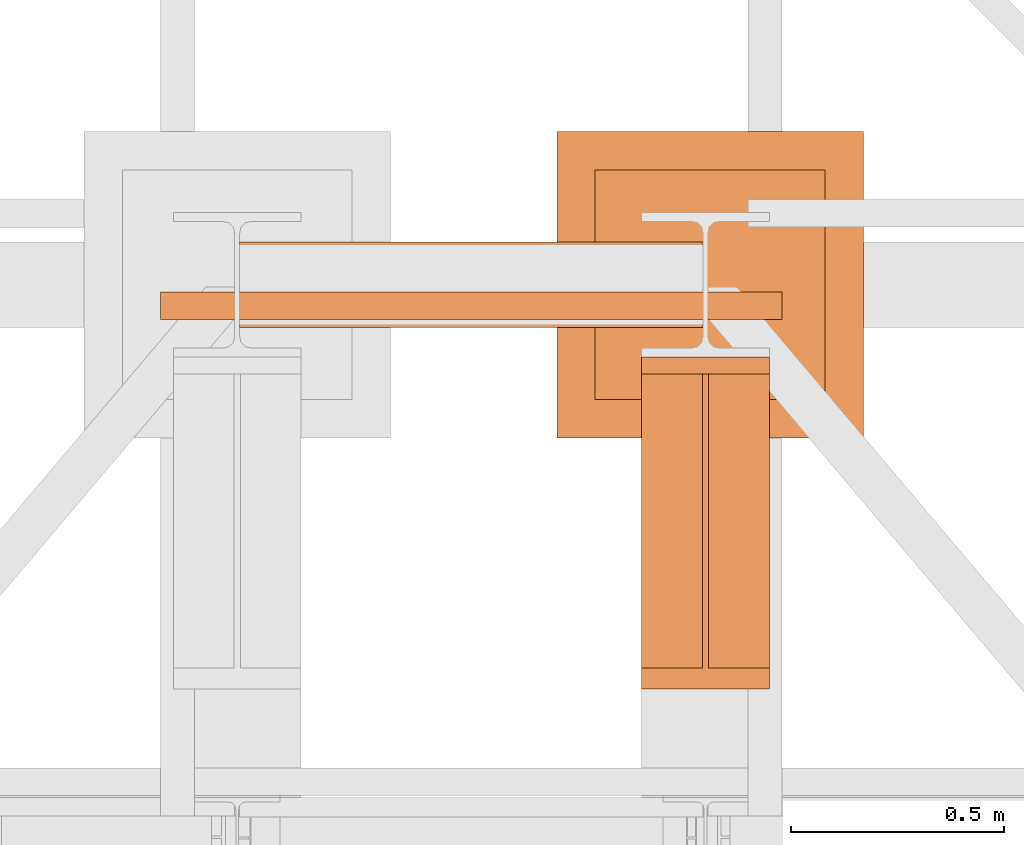
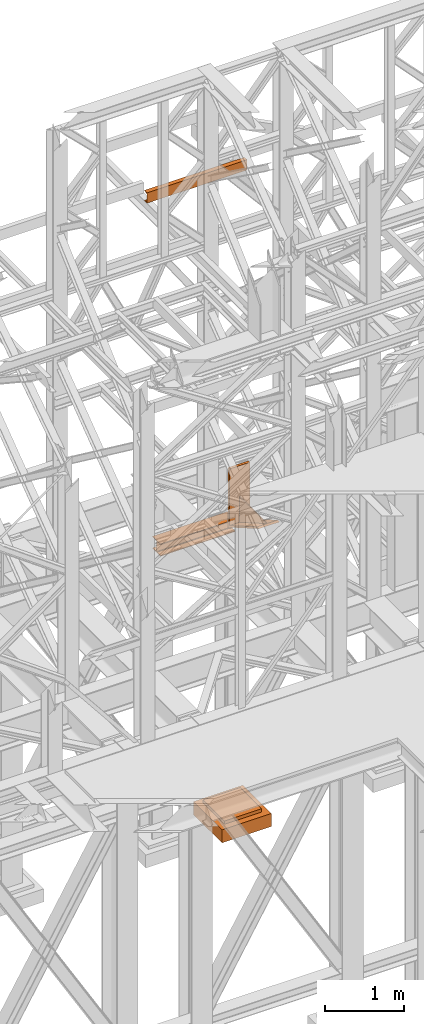
# One storey, part 195 of 208: 4 proxies.
"""IFC2X3 building model written with IfcOpenShell, lengths in millimetres."""

import ifcopenshell
import ifcopenshell.guid

model = None  # the IFC model being written
_history = None  # IfcOwnerHistory: only IFC2X3 demands one
_inside = {}  # id of a spatial element -> (the spatial element, [elements in it])
_under = {}  # id of a project, library or spatial element -> (it, [spatial elements below it])
_declared = {}  # id of a project -> (the project, [libraries it declares])
_typed = {}  # id of a type object -> (the type object, [elements of that type])
_made_of = {}  # id of a material, layer set ... -> (it, [elements and type objects made of it])


def new_model(schema):
    """Start an empty IFC model of exactly this schema.

    Asked for "IFC4X3", IfcOpenShell would pick the latest addendum, in which some entities
    have other attributes; the version numbers below select the first issue.
    IFC2X3 requires an IfcOwnerHistory on every rooted entity: one is made here for all.
    """
    global model, _history
    if schema == "IFC4X3":
        model = ifcopenshell.file(schema_version=(4, 3, 0, 0))
    else:
        model = ifcopenshell.file(schema=schema)
    _inside.clear()
    _under.clear()
    _declared.clear()
    _typed.clear()
    _made_of.clear()
    _history = None
    if model.schema == "IFC2X3":
        org = make("IfcOrganization", Name="unknown")
        user = make(
            "IfcPersonAndOrganization",
            ThePerson=make("IfcPerson", FamilyName="unknown"),
            TheOrganization=org,
        )
        app = make(
            "IfcApplication",
            ApplicationDeveloper=org,
            Version="unknown",
            ApplicationFullName="unknown",
            ApplicationIdentifier="unknown",
        )
        _history = make(
            "IfcOwnerHistory",
            OwningUser=user,
            OwningApplication=app,
            ChangeAction="ADDED",
            CreationDate=0,
        )
    return model


def make(cls, **values):
    """One entity of the class cls with the attributes given. An attribute that is None is left unset."""
    return model.create_entity(
        cls, **{name: value for name, value in values.items() if value is not None}
    )


def entity(cls, *values):
    """Any entity or typed value of the class cls, its attributes in the order of the schema. None: left unset."""
    e = model.create_entity(cls)
    for i, value in enumerate(values):
        if value is not None:
            e[i] = value
    return e


def rooted(cls, **values):
    """An entity with a GlobalId (a new one), such as an element, a storey or a relation."""
    return make(cls, GlobalId=ifcopenshell.guid.new(), OwnerHistory=_history, **values)


def si_unit(unit_type, name, prefix=None):
    """IfcSIUnit, for example si_unit("LENGTHUNIT", "METRE", prefix="MILLI")."""
    return make("IfcSIUnit", UnitType=unit_type, Prefix=prefix, Name=name)


def converted_unit(unit_type, name, factor, base, dimensions=None, offset=None):
    """IfcConversionBasedUnit, such as the inch: factor (a typed value) times the base unit."""
    return make(
        "IfcConversionBasedUnit"
        if offset is None
        else "IfcConversionBasedUnitWithOffset",
        ConversionOffset=offset,
        Dimensions=None
        if dimensions is None
        else entity("IfcDimensionalExponents", *dimensions),
        UnitType=unit_type,
        Name=name,
        ConversionFactor=make(
            "IfcMeasureWithUnit", ValueComponent=factor, UnitComponent=base
        ),
    )


def assignment(units):
    """IfcUnitAssignment: the units of a project."""
    return None if units is None else make("IfcUnitAssignment", Units=units)


def point(xyz):
    """IfcCartesianPoint."""
    return None if xyz is None else make("IfcCartesianPoint", Coordinates=xyz)


def direction(xyz):
    """IfcDirection."""
    return None if xyz is None else make("IfcDirection", DirectionRatios=xyz)


def frame(location, z_axis=None, x_axis=None):
    """IfcAxis2Placement3D, a coordinate frame: its origin and axes. An axis left out is left unset."""
    return make(
        "IfcAxis2Placement3D",
        Location=point(location),
        Axis=direction(z_axis),
        RefDirection=direction(x_axis),
    )


def origin():
    """The frame at (0, 0, 0) with its axes left unset."""
    return frame((0.0, 0.0, 0.0))


def origin_with_axes():
    """The frame at (0, 0, 0) with the z axis (0, 0, 1) and the x axis (1, 0, 0) written out."""
    return frame((0.0, 0.0, 0.0), z_axis=(0.0, 0.0, 1.0), x_axis=(1.0, 0.0, 0.0))


def place(relative_to, where):
    """IfcLocalPlacement: puts the frame where relative to a parent placement (None: the world)."""
    return make(
        "IfcLocalPlacement", PlacementRelTo=relative_to, RelativePlacement=where
    )


def context(
    kind, dimensions, precision=None, world=None, true_north=None, identifier=None
):
    """IfcGeometricRepresentationContext, for example the 3D "Model" context."""
    return make(
        "IfcGeometricRepresentationContext",
        ContextIdentifier=identifier,
        ContextType=kind,
        CoordinateSpaceDimension=dimensions,
        Precision=precision,
        WorldCoordinateSystem=world,
        TrueNorth=true_north,
    )


def subcontext(parent, identifier, kind, view, scale=None):
    """IfcGeometricRepresentationSubContext, for example "Body" below "Model"."""
    return make(
        "IfcGeometricRepresentationSubContext",
        ContextIdentifier=identifier,
        ContextType=kind,
        ParentContext=parent,
        TargetScale=scale,
        TargetView=view,
    )


def project(units=None, contexts=None):
    """IfcProject with its units and contexts."""
    return rooted(
        "IfcProject",
        Name="project",
        RepresentationContexts=contexts,
        UnitsInContext=assignment(units),
    )


def spatial(cls, under=None, at=None, **own):
    """A site, building, storey or space (cls), placed at a placement, below another one or the project."""
    s = rooted(cls, ObjectPlacement=at, **own)
    if under is not None:
        _under.setdefault(under.id(), (under, []))[1].append(s)
    return s


def faces_of(points, faces, orient=None, outer=None):
    """IfcFace entities. A face is a list of loops; a loop is a list of indices into points, from 0.

    orient and outer hold one flag for each loop. By default every Orientation is true, the
    first loop of a face is its IfcFaceOuterBound and the others are IfcFaceBound.
    """
    made = []
    for i, loops in enumerate(faces):
        bounds = []
        for j, loop in enumerate(loops):
            is_outer = j == 0 if outer is None else outer[i][j]
            bounds.append(
                make(
                    "IfcFaceOuterBound" if is_outer else "IfcFaceBound",
                    Bound=make("IfcPolyLoop", Polygon=[points[k] for k in loop]),
                    Orientation=True if orient is None else orient[i][j],
                )
            )
        made.append(make("IfcFace", Bounds=bounds))
    return made


def faceted_brep(points, faces, orient=None, outer=None, voids=None):
    """IfcFacetedBrep: a solid bounded by flat faces; with voids (closed shells), ...WithVoids."""
    shared = [point(p) for p in points]
    hull = make("IfcClosedShell", CfsFaces=faces_of(shared, faces, orient, outer))
    if voids is None:
        return make("IfcFacetedBrep", Outer=hull)
    return make(
        "IfcFacetedBrepWithVoids",
        Outer=hull,
        Voids=[
            make(cls, CfsFaces=faces_of(shared, fs, o, b)) for cls, fs, o, b in voids
        ],
    )


def shape(context_of_items, identifier, shape_type, items):
    """IfcShapeRepresentation: the items that make up one representation, for example the "Body"."""
    return make(
        "IfcShapeRepresentation",
        ContextOfItems=context_of_items,
        RepresentationIdentifier=identifier,
        RepresentationType=shape_type,
        Items=items,
    )


def made_of(thing, what):
    """Note that an element or type object is made of a material, layer set ...; save() writes the relation."""
    if what is not None:
        _made_of.setdefault(what.id(), (what, []))[1].append(thing)
    return thing


def element(
    cls,
    number,
    at=None,
    inside=None,
    cuts=None,
    type_object=None,
    material=None,
    context=None,
    identifier="Body",
    shape_type=None,
    held_by="IfcProductDefinitionShape",
    body=None,
    shapes=None,
    **own,
):
    """One element of the class cls, such as IfcWall. Its Tag is "e" and its number.

    at: its placement. inside: the storey or other place that contains it. cuts: it is an
    opening in that element (IfcRelVoidsElement). A single representation is given by context,
    identifier, shape_type and body (its items); several are given by shapes. held_by: the class
    of the entity that holds the representations. save() writes the other relations.
    """
    e = rooted(cls, Tag="e%d" % number, ObjectPlacement=at, **own)
    if body is not None:
        shapes = [shape(context, identifier, shape_type, body)]
    if shapes is not None:
        e.Representation = make(held_by, Representations=shapes)
    if inside is not None:
        _inside.setdefault(inside.id(), (inside, []))[1].append(e)
    if cuts is not None:
        rooted(
            "IfcRelVoidsElement", RelatingBuildingElement=cuts, RelatedOpeningElement=e
        )
    if type_object is not None:
        _typed.setdefault(type_object.id(), (type_object, []))[1].append(e)
    return made_of(e, material)


def aggregate(whole, parts):
    """IfcRelAggregates: a whole, such as a stair, and the parts it consists of."""
    return rooted("IfcRelAggregates", RelatingObject=whole, RelatedObjects=parts)


def save(model, path):
    """Write the relations noted so far, then the file.

    IfcRelAggregates (storeys below a building ...), IfcRelContainedInSpatialStructure (elements
    in a storey), IfcRelDefinesByType, IfcRelAssociatesMaterial and IfcRelDeclares: one each for
    every whole, place, type object, material and project.
    """
    for whole, parts in _under.values():
        aggregate(whole, parts)
    for where, things in _inside.values():
        rooted(
            "IfcRelContainedInSpatialStructure",
            RelatedElements=things,
            RelatingStructure=where,
        )
    for kind, things in _typed.values():
        rooted("IfcRelDefinesByType", RelatedObjects=things, RelatingType=kind)
    for what, things in _made_of.values():
        rooted("IfcRelAssociatesMaterial", RelatedObjects=things, RelatingMaterial=what)
    for by, libraries in _declared.values():
        rooted("IfcRelDeclares", RelatingContext=by, RelatedDefinitions=libraries)
    model.write(path)


model = new_model("IFC2X3")

# Units and contexts
model_context = context("Model", 3, precision=1e-05, world=origin())
plan_context = context("Plan", 3, precision=1e-05, world=origin())
body_context = subcontext(model_context, "Body", "Model", "MODEL_VIEW")
ifc_project = project(units=[si_unit("LENGTHUNIT", "METRE", prefix="MILLI"), converted_unit("PLANEANGLEUNIT", "DEGREE", entity("IfcPlaneAngleMeasure", 0.0174532925199433), si_unit("PLANEANGLEUNIT", "RADIAN"), dimensions=[0, 0, 0, 0, 0, 0, 0]), si_unit("AREAUNIT", "SQUARE_METRE"), si_unit("VOLUMEUNIT", "CUBIC_METRE")], contexts=[model_context, plan_context])

# Building, storey
building_placement = place(None, origin())
building = spatial("IfcBuilding", under=ifc_project, at=building_placement, CompositionType="COMPLEX")
storey_placement = place(building_placement, origin_with_axes())
storey = spatial("IfcBuildingStorey", under=building, at=storey_placement, Name="Geschoss", CompositionType="ELEMENT")

# Proxies
proxy_1_placement = place(storey_placement, frame((5499.254968580821, -12562.57439501764, 4202.989992847441), z_axis=(0.0, 0.0, 1.0), x_axis=(1.0, 0.0, 0.0)))
element("IfcBuildingElementProxy", 1, at=proxy_1_placement, inside=storey, context=body_context, shape_type="Brep", body=[
    faceted_brep([(1088.009999895692, 0.01000000000021828, 190.0100125169756), (1088.009999895692, 200.0100029802325, 190.0100125169756), (1088.009999895692, 200.0100029802325, 180.0100146031382), (1088.009999895692, 121.2600035762789, 180.0100071525576), (1088.009999895692, 111.9441915473344, 178.1454621052744), (1088.009999895692, 105.1245498640838, 171.3258190250399), (1088.009999895692, 103.2600015571716, 162.010007927418), (1088.009999895692, 103.2600015571716, 28.00999713897727), (1088.009999895692, 105.1245498640838, 18.69418604135535), (1088.009999895692, 111.9441915473344, 11.87454296112082), (1088.009999895692, 121.2600035762789, 10.00999791383765), (1088.009999895692, 200.0100029802325, 10.00999791383765), (1088.009999895692, 200.0100029802325, 0.01000000000021828), (1088.009999895692, 0.01000000000021828, 0.01000000000021828), (1088.009999895692, 0.01000000000021828, 10.00999791383765), (1088.009999895692, 78.75999940395377, 10.00999791383765), (1088.009999895692, 88.07581143289826, 11.87454296112082), (1088.009999895692, 94.89545311614893, 18.69418604135535), (1088.009999895692, 96.76000142306111, 28.00999713897727), (1088.009999895692, 96.76000142306111, 162.010007927418), (1088.009999895692, 94.89545311614893, 171.3258190250399), (1088.009999895692, 88.07581143289826, 178.1454621052744), (1088.009999895692, 78.75999940395377, 180.0100071525576), (1088.009999895692, 0.01000000000021828, 180.0100146031382), (1088.009999895692, 200.0100029802325, 190.0100125169756), (1088.009999895692, 0.01000000000021828, 190.0100125169756), (0.01000000000021828, 0.01000000000021828, 190.0100125169756), (0.01000000000021828, 200.0100029802325, 190.0100125169756), (1088.009999895692, 200.0100029802325, 180.0100146031382), (1088.009999895692, 200.0100029802325, 190.0100125169756), (0.01000000000021828, 200.0100029802325, 190.0100125169756), (0.01000000000021828, 200.0100029802325, 180.0100146031382), (1088.009999895692, 121.2600035762789, 180.0100071525576), (1088.009999895692, 200.0100029802325, 180.0100146031382), (0.01000000000021828, 200.0100029802325, 180.0100146031382), (0.01000000000021828, 121.2600035762789, 180.0100071525576), (1088.009999895692, 111.9441915473344, 178.1454621052744), (1088.009999895692, 121.2600035762789, 180.0100071525576), (0.01000000000021828, 121.2600035762789, 180.0100071525576), (0.01000000000021828, 111.9441915473344, 178.1454621052744), (1088.009999895692, 105.1245498640838, 171.3258190250399), (1088.009999895692, 111.9441915473344, 178.1454621052744), (0.01000000000021828, 111.9441915473344, 178.1454621052744), (0.01000000000021828, 105.1245498640838, 171.3258190250399), (1088.009999895692, 103.2600015571716, 162.010007927418), (1088.009999895692, 105.1245498640838, 171.3258190250399), (0.01000000000021828, 105.1245498640838, 171.3258190250399), (0.01000000000021828, 103.2600015571716, 162.010007927418), (1088.009999895692, 103.2600015571716, 28.00999713897727), (1088.009999895692, 103.2600015571716, 162.010007927418), (0.01000000000021828, 103.2600015571716, 162.010007927418), (0.01000000000021828, 103.2600015571716, 28.00999713897727), (1088.009999895692, 105.1245498640838, 18.69418604135535), (1088.009999895692, 103.2600015571716, 28.00999713897727), (0.01000000000021828, 103.2600015571716, 28.00999713897727), (0.01000000000021828, 105.1245498640838, 18.69418604135535), (1088.009999895692, 111.9441915473344, 11.87454296112082), (1088.009999895692, 105.1245498640838, 18.69418604135535), (0.01000000000021828, 105.1245498640838, 18.69418604135535), (0.01000000000021828, 111.9441915473344, 11.87454296112082), (1088.009999895692, 121.2600035762789, 10.00999791383765), (1088.009999895692, 111.9441915473344, 11.87454296112082), (0.01000000000021828, 111.9441915473344, 11.87454296112082), (0.01000000000021828, 121.2600035762789, 10.00999791383765), (1088.009999895692, 200.0100029802325, 10.00999791383765), (1088.009999895692, 121.2600035762789, 10.00999791383765), (0.01000000000021828, 121.2600035762789, 10.00999791383765), (0.01000000000021828, 200.0100029802325, 10.00999791383765), (1088.009999895692, 200.0100029802325, 0.01000000000021828), (1088.009999895692, 200.0100029802325, 10.00999791383765), (0.01000000000021828, 200.0100029802325, 10.00999791383765), (0.01000000000021828, 200.0100029802325, 0.01000000000021828), (1088.009999895692, 0.01000000000021828, 0.01000000000021828), (1088.009999895692, 200.0100029802325, 0.01000000000021828), (0.01000000000021828, 200.0100029802325, 0.01000000000021828), (0.01000000000021828, 0.01000000000021828, 0.01000000000021828), (1088.009999895692, 0.01000000000021828, 10.00999791383765), (1088.009999895692, 0.01000000000021828, 0.01000000000021828), (0.01000000000021828, 0.01000000000021828, 0.01000000000021828), (0.01000000000021828, 0.01000000000021828, 10.00999791383765), (1088.009999895692, 78.75999940395377, 10.00999791383765), (1088.009999895692, 0.01000000000021828, 10.00999791383765), (0.01000000000021828, 0.01000000000021828, 10.00999791383765), (0.01000000000021828, 78.75999940395377, 10.00999791383765), (1088.009999895692, 88.07581143289826, 11.87454296112082), (1088.009999895692, 78.75999940395377, 10.00999791383765), (0.01000000000021828, 78.75999940395377, 10.00999791383765), (0.01000000000021828, 88.07581143289826, 11.87454296112082), (1088.009999895692, 94.89545311614893, 18.69418604135535), (1088.009999895692, 88.07581143289826, 11.87454296112082), (0.01000000000021828, 88.07581143289826, 11.87454296112082), (0.01000000000021828, 94.89545311614893, 18.69418604135535), (1088.009999895692, 96.76000142306111, 28.00999713897727), (1088.009999895692, 94.89545311614893, 18.69418604135535), (0.01000000000021828, 94.89545311614893, 18.69418604135535), (0.01000000000021828, 96.76000142306111, 28.00999713897727), (1088.009999895692, 96.76000142306111, 162.010007927418), (1088.009999895692, 96.76000142306111, 28.00999713897727), (0.01000000000021828, 96.76000142306111, 28.00999713897727), (0.01000000000021828, 96.76000142306111, 162.010007927418), (1088.009999895692, 94.89545311614893, 171.3258190250399), (1088.009999895692, 96.76000142306111, 162.010007927418), (0.01000000000021828, 96.76000142306111, 162.010007927418), (0.01000000000021828, 94.89545311614893, 171.3258190250399), (1088.009999895692, 88.07581143289826, 178.1454621052744), (1088.009999895692, 94.89545311614893, 171.3258190250399), (0.01000000000021828, 94.89545311614893, 171.3258190250399), (0.01000000000021828, 88.07581143289826, 178.1454621052744), (1088.009999895692, 78.75999940395377, 180.0100071525576), (1088.009999895692, 88.07581143289826, 178.1454621052744), (0.01000000000021828, 88.07581143289826, 178.1454621052744), (0.01000000000021828, 78.75999940395377, 180.0100071525576), (1088.009999895692, 0.01000000000021828, 180.0100146031382), (1088.009999895692, 78.75999940395377, 180.0100071525576), (0.01000000000021828, 78.75999940395377, 180.0100071525576), (0.01000000000021828, 0.01000000000021828, 180.0100146031382), (1088.009999895692, 0.01000000000021828, 190.0100125169756), (1088.009999895692, 0.01000000000021828, 180.0100146031382), (0.01000000000021828, 0.01000000000021828, 180.0100146031382), (0.01000000000021828, 0.01000000000021828, 190.0100125169756), (0.01000000000021828, 0.01000000000021828, 190.0100125169756), (0.01000000000021828, 0.01000000000021828, 180.0100146031382), (0.01000000000021828, 78.75999940395377, 180.0100071525576), (0.01000000000021828, 88.07581143289826, 178.1454621052744), (0.01000000000021828, 94.89545311614893, 171.3258190250399), (0.01000000000021828, 96.76000142306111, 162.010007927418), (0.01000000000021828, 96.76000142306111, 28.00999713897727), (0.01000000000021828, 94.89545311614893, 18.69418604135535), (0.01000000000021828, 88.07581143289826, 11.87454296112082), (0.01000000000021828, 78.75999940395377, 10.00999791383765), (0.01000000000021828, 0.01000000000021828, 10.00999791383765), (0.01000000000021828, 0.01000000000021828, 0.01000000000021828), (0.01000000000021828, 200.0100029802325, 0.01000000000021828), (0.01000000000021828, 200.0100029802325, 10.00999791383765), (0.01000000000021828, 121.2600035762789, 10.00999791383765), (0.01000000000021828, 111.9441915473344, 11.87454296112082), (0.01000000000021828, 105.1245498640838, 18.69418604135535), (0.01000000000021828, 103.2600015571716, 28.00999713897727), (0.01000000000021828, 103.2600015571716, 162.010007927418), (0.01000000000021828, 105.1245498640838, 171.3258190250399), (0.01000000000021828, 111.9441915473344, 178.1454621052744), (0.01000000000021828, 121.2600035762789, 180.0100071525576), (0.01000000000021828, 200.0100029802325, 180.0100146031382), (0.01000000000021828, 200.0100029802325, 190.0100125169756)], [[[0, 1, 2, 3, 4, 5, 6, 7, 8, 9, 10, 11, 12, 13, 14, 15, 16, 17, 18, 19, 20, 21, 22, 23]], [[24, 25, 26, 27]], [[28, 29, 30, 31]], [[32, 33, 34, 35]], [[36, 37, 38, 39]], [[40, 41, 42, 43]], [[44, 45, 46, 47]], [[48, 49, 50, 51]], [[52, 53, 54, 55]], [[56, 57, 58, 59]], [[60, 61, 62, 63]], [[64, 65, 66, 67]], [[68, 69, 70, 71]], [[72, 73, 74, 75]], [[76, 77, 78, 79]], [[80, 81, 82, 83]], [[84, 85, 86, 87]], [[88, 89, 90, 91]], [[92, 93, 94, 95]], [[96, 97, 98, 99]], [[100, 101, 102, 103]], [[104, 105, 106, 107]], [[108, 109, 110, 111]], [[112, 113, 114, 115]], [[116, 117, 118, 119]], [[120, 121, 122, 123, 124, 125, 126, 127, 128, 129, 130, 131, 132, 133, 134, 135, 136, 137, 138, 139, 140, 141, 142, 143]]], orient=[[False], [False], [False], [False], [False], [False], [False], [False], [False], [False], [False], [False], [False], [False], [False], [False], [False], [False], [False], [False], [False], [False], [False], [False], [False], [False]]),
])
proxy_2_placement = place(storey_placement, frame((6443.254974489131, -13412.43639531565, 4367.230005364415), z_axis=(0.0, 0.0, 1.0), x_axis=(1.0, 0.0, 0.0)))
element("IfcBuildingElementProxy", 2, at=proxy_2_placement, inside=storey, context=body_context, shape_type="Brep", body=[
    faceted_brep([(0.01000000000021828, 739.8719999999976, 18.61000000000058), (0.01000000000021828, 0.00999999999839929, 445.7700000000004), (300.0100000000002, 0.00999999999839929, 445.7700000000004), (300.0100000000002, 739.8719999999976, 18.61000000000058), (0.01000000000021828, 0.00999999999839929, 445.7700000000004), (0.01000000000021828, 50.06599999999889, 445.7710000000006), (142.5100000000002, 50.06599999999708, 445.7710000000006), (142.5100000000002, 739.8719999999976, 445.7700000000004), (157.5100000000002, 739.8719999999976, 445.7700000000004), (157.5100000000002, 50.06599999999708, 445.7710000000006), (300.0100000000002, 50.06599999999708, 445.7710000000006), (300.0100000000002, 0.00999999999839929, 445.7700000000004), (0.01000000000021828, 50.06599999999889, 445.7710000000006), (0.01000000000021828, 739.8719999999976, 47.51000000000022), (142.5100000000002, 739.8719999999976, 47.51000000000022), (142.5100000000002, 50.06599999999708, 445.7710000000006), (157.5100000000002, 739.8719999999976, 47.51000000000022), (300.0100000000002, 739.8719999999976, 47.51000000000022), (300.0100000000002, 50.06599999999708, 445.7710000000006), (157.5100000000002, 50.06599999999708, 445.7710000000006), (0.01000000000021828, 739.8719999999976, 18.61000000000058), (0.01000000000021828, 739.8719999999976, 0.01000000000021828), (0.01000000000021828, 779.8719999999976, 0.01000000000021828), (0.01000000000021828, 779.8719999999976, 917.7700000000013), (0.01000000000021828, 739.8719999999976, 917.7700000000013), (0.01000000000021828, 739.8719999999976, 47.51000000000022), (0.01000000000021828, 50.06599999999889, 445.7710000000006), (0.01000000000021828, 0.00999999999839929, 445.7700000000004), (300.0100000000002, 779.8719999999976, 917.7700000000013), (300.0100000000002, 779.8719999999976, 0.01000000000021828), (300.0100000000002, 739.8719999999976, 0.01000000000021828), (300.0100000000002, 739.8719999999976, 18.61000000000058), (300.0100000000002, 0.00999999999839929, 445.7700000000004), (300.0100000000002, 50.06599999999708, 445.7710000000006), (300.0100000000002, 739.8719999999976, 47.51000000000022), (300.0100000000002, 739.8719999999976, 917.7700000000013), (300.0100000000002, 779.8719999999976, 917.7700000000013), (300.0100000000002, 739.8719999999976, 917.7700000000013), (0.01000000000021828, 739.8719999999976, 917.7700000000013), (0.01000000000021828, 779.8719999999976, 917.7700000000013), (300.0100000000002, 739.8719999999976, 917.7700000000013), (300.0100000000002, 739.8719999999976, 47.51000000000022), (157.5100000000002, 739.8719999999976, 47.51000000000022), (157.5100000000002, 739.8719999999976, 445.7700000000004), (142.5100000000002, 739.8719999999976, 445.7700000000004), (142.5100000000002, 739.8719999999976, 47.51000000000022), (0.01000000000021828, 739.8719999999976, 47.51000000000022), (0.01000000000021828, 739.8719999999976, 917.7700000000013), (300.0100000000002, 739.8719999999976, 18.61000000000058), (300.0100000000002, 739.8719999999976, 0.01000000000021828), (0.01000000000021828, 739.8719999999976, 0.01000000000021828), (0.01000000000021828, 739.8719999999976, 18.61000000000058), (300.0100000000002, 739.8719999999976, 0.01000000000021828), (300.0100000000002, 779.8719999999976, 0.01000000000021828), (0.01000000000021828, 779.8719999999976, 0.01000000000021828), (0.01000000000021828, 739.8719999999976, 0.01000000000021828), (300.0100000000002, 779.8719999999976, 0.01000000000021828), (300.0100000000002, 779.8719999999976, 917.7700000000013), (0.01000000000021828, 779.8719999999976, 917.7700000000013), (0.01000000000021828, 779.8719999999976, 0.01000000000021828), (142.5100000000002, 739.8719999999976, 47.51000000000022), (142.5100000000002, 739.8719999999976, 445.7700000000004), (142.5100000000002, 50.06599999999708, 445.7710000000006), (157.5100000000002, 739.8719999999976, 47.51000000000022), (157.5100000000002, 50.06599999999708, 445.7710000000006), (157.5100000000002, 739.8719999999976, 445.7700000000004)], [[[0, 1, 2, 3]], [[4, 5, 6, 7, 8, 9, 10, 11]], [[12, 13, 14, 15]], [[16, 17, 18, 19]], [[20, 21, 22, 23, 24, 25, 26, 27]], [[28, 29, 30, 31, 32, 33, 34, 35]], [[36, 37, 38, 39]], [[40, 41, 42, 43, 44, 45, 46, 47]], [[48, 49, 50, 51]], [[52, 53, 54, 55]], [[56, 57, 58, 59]], [[60, 61, 62]], [[63, 64, 65]]], orient=[[False], [False], [False], [False], [False], [False], [False], [False], [False], [False], [False], [False], [False]]),
])
proxy_3_placement = place(storey_placement, frame((6244.358622037166, -12822.57439725281, -315.01), z_axis=(0.0, 0.0, 1.0), x_axis=(1.0, 0.0, 0.0)))
element("IfcBuildingElementProxy", 3, at=proxy_3_placement, inside=storey, context=body_context, shape_type="Brep", body=[
    faceted_brep([(630.0100000000002, 630.0100000000002, 250.01), (630.0100000000002, 90.01000000000022, 250.01), (90.01000000000022, 90.01000000000022, 250.01), (90.01000000000022, 630.0100000000002, 250.01), (630.0100000000002, 630.0100000000002, 200.01), (630.0100000000002, 90.01000000000022, 200.01), (630.0100000000002, 90.01000000000022, 250.01), (630.0100000000002, 630.0100000000002, 250.01), (90.01000000000022, 630.0100000000002, 200.01), (630.0100000000002, 630.0100000000002, 200.01), (630.0100000000002, 630.0100000000002, 250.01), (90.01000000000022, 630.0100000000002, 250.01), (90.01000000000022, 90.01000000000022, 200.01), (90.01000000000022, 630.0100000000002, 200.01), (90.01000000000022, 630.0100000000002, 250.01), (90.01000000000022, 90.01000000000022, 250.01), (630.0100000000002, 90.01000000000022, 200.01), (90.01000000000022, 90.01000000000022, 200.01), (90.01000000000022, 90.01000000000022, 250.01), (630.0100000000002, 90.01000000000022, 250.01), (720.0100000000002, 0.01000000000021828, 0.009999999999990905), (720.0100000000002, 720.0100000000002, 0.009999999999990905), (0.01000000000021828, 720.0100000000002, 0.009999999999990905), (0.01000000000021828, 0.01000000000021828, 0.009999999999990905), (720.0100000000002, 720.0100000000002, 200.01), (720.0100000000002, 0.01000000000021828, 200.01), (0.01000000000021828, 0.01000000000021828, 200.01), (0.01000000000021828, 720.0100000000002, 200.01), (90.01000000000022, 90.01000000000022, 200.01), (630.0100000000002, 90.01000000000022, 200.01), (630.0100000000002, 630.0100000000002, 200.01), (90.01000000000022, 630.0100000000002, 200.01), (720.0100000000002, 720.0100000000002, 0.009999999999990905), (720.0100000000002, 0.01000000000021828, 0.009999999999990905), (720.0100000000002, 0.01000000000021828, 200.01), (720.0100000000002, 720.0100000000002, 200.01), (0.01000000000021828, 720.0100000000002, 0.009999999999990905), (720.0100000000002, 720.0100000000002, 0.009999999999990905), (720.0100000000002, 720.0100000000002, 200.01), (0.01000000000021828, 720.0100000000002, 200.01), (0.01000000000021828, 0.01000000000021828, 0.009999999999990905), (0.01000000000021828, 720.0100000000002, 0.009999999999990905), (0.01000000000021828, 720.0100000000002, 200.01), (0.01000000000021828, 0.01000000000021828, 200.01), (720.0100000000002, 0.01000000000021828, 0.009999999999990905), (0.01000000000021828, 0.01000000000021828, 0.009999999999990905), (0.01000000000021828, 0.01000000000021828, 200.01), (720.0100000000002, 0.01000000000021828, 200.01)], [[[0, 1, 2, 3]], [[4, 5, 6, 7]], [[8, 9, 10, 11]], [[12, 13, 14, 15]], [[16, 17, 18, 19]], [[20, 21, 22, 23]], [[24, 25, 26, 27], [28, 29, 30, 31]], [[32, 33, 34, 35]], [[36, 37, 38, 39]], [[40, 41, 42, 43]], [[44, 45, 46, 47]]], orient=[[False], [False], [False], [False], [False], [False], [False, False], [False], [False], [False], [False]]),
])
proxy_4_placement = place(storey_placement, frame((5313.254967038552, -12544.51674478295, 9699.99), z_axis=(0.0, 0.0, 1.0), x_axis=(1.0, 0.0, 0.0)))
element("IfcBuildingElementProxy", 4, at=proxy_4_placement, inside=storey, context=body_context, shape_type="Brep", body=[
    faceted_brep([(0.009999999999308784, 65.01000000000022, 0.01000000000021828), (1460.010002980231, 65.01000000000022, 0.01000000000021828), (1460.010002980231, 65.01000000000022, 3.132428070246533), (0.009999999999308784, 65.01000000000022, 3.132428070246533), (0.009999999999308784, 65.01000000000022, 3.132428070246533), (1460.010002980231, 65.01000000000022, 3.132428070246533), (1460.010002980231, 64.76726342282564, 4.748288908171162), (0.009999999999308784, 64.76726342282745, 4.748288908171162), (0.009999999999308784, 64.76726342282745, 4.748288908171162), (1460.010002980231, 64.76726342282564, 4.748288908171162), (1460.010002980231, 64.06053228585552, 6.221534443444398), (0.009999999999308784, 64.06053228585733, 6.221534443444398), (0.009999999999308784, 64.06053228585733, 6.221534443444398), (1460.010002980231, 64.06053228585552, 6.221534443444398), (1460.010002980231, 62.95215163846842, 7.422126703873801), (0.009999999999308784, 62.95215163846842, 7.422126703873801), (0.009999999999308784, 62.95215163846842, 7.422126703873801), (1460.010002980231, 62.95215163846842, 7.422126703873801), (1460.010002980231, 61.53995641148322, 8.244091391710754), (0.009999999999308784, 61.53995641148504, 8.244091391710754), (0.009999999999308784, 61.53995641148504, 8.244091391710754), (1460.010002980231, 61.53995641148322, 8.244091391710754), (1460.010002980231, 59.94859872255438, 8.614912102195376), (0.009999999999308784, 59.9485987225562, 8.614912102195376), (0.009999999999308784, 59.9485987225562, 8.614912102195376), (1460.010002980231, 59.94859872255438, 8.614912102195376), (1460.010002980231, 17.17267516602988, 12.0369859867169), (0.009999999999308784, 17.17267516602988, 12.0369859867169), (0.009999999999308784, 17.17267516602988, 12.0369859867169), (1460.010002980231, 17.17267516602988, 12.0369859867169), (1460.010002980231, 14.13462866898226, 12.74491643400506), (0.009999999999308784, 14.13462866898408, 12.74491643400506), (0.009999999999308784, 14.13462866898408, 12.74491643400506), (1460.010002980231, 14.13462866898226, 12.74491643400506), (1460.010002980231, 11.43861959928654, 14.31412174714933), (0.009999999999308784, 11.43861959928654, 14.31412174714933), (0.009999999999308784, 11.43861959928654, 14.31412174714933), (1460.010002980231, 11.43861959928654, 14.31412174714933), (1460.010002980231, 9.322620181546881, 16.60616151705835), (0.009999999999308784, 9.322620181546881, 16.60616151705835), (0.009999999999308784, 9.322620181546881, 16.60616151705835), (1460.010002980231, 9.322620181546881, 16.60616151705835), (1460.010002980231, 7.97340619278657, 19.41872117530875), (0.009999999999308784, 7.97340619278657, 19.41872117530875), (0.009999999999308784, 7.97340619278657, 19.41872117530875), (1460.010002980231, 7.97340619278657, 19.41872117530875), (1460.010002980231, 7.510000000000218, 22.50354641134618), (0.009999999999308784, 7.510000000000218, 22.50354641134618), (0.009999999999308784, 7.510000000000218, 22.50354641134618), (1460.010002980231, 7.510000000000218, 22.50354641134618), (1460.010002980231, 7.510000000000218, 137.5164535886524), (0.009999999999308784, 7.510000000000218, 137.5164535886524), (0.009999999999308784, 7.510000000000218, 137.5164535886524), (1460.010002980231, 7.510000000000218, 137.5164535886524), (1460.010002980231, 7.97340619278657, 140.6012788246917), (0.009999999999308784, 7.97340619278657, 140.6012788246917), (0.009999999999308784, 7.97340619278657, 140.6012788246917), (1460.010002980231, 7.97340619278657, 140.6012788246917), (1460.010002980231, 9.322620181546881, 143.4138384829403), (0.009999999999308784, 9.322620181546881, 143.4138384829403), (0.009999999999308784, 9.322620181546881, 143.4138384829403), (1460.010002980231, 9.322620181546881, 143.4138384829403), (1460.010002980231, 11.43861959928654, 145.7058782528493), (0.009999999999308784, 11.43861959928654, 145.7058782528493), (0.009999999999308784, 11.43861959928654, 145.7058782528493), (1460.010002980231, 11.43861959928654, 145.7058782528493), (1460.010002980231, 14.13462866898226, 147.2750835659936), (0.009999999999308784, 14.13462866898408, 147.2750835659936), (0.009999999999308784, 14.13462866898408, 147.2750835659936), (1460.010002980231, 14.13462866898226, 147.2750835659936), (1460.010002980231, 17.17267516602988, 147.9830140132817), (0.009999999999308784, 17.17267516602988, 147.9830140132817), (0.009999999999308784, 17.17267516602988, 147.9830140132817), (1460.010002980231, 17.17267516602988, 147.9830140132817), (1460.010002980231, 59.94859872255438, 151.4050878978032), (0.009999999999308784, 59.9485987225562, 151.4050878978032), (0.009999999999308784, 59.9485987225562, 151.4050878978032), (1460.010002980231, 59.94859872255438, 151.4050878978032), (1460.010002980231, 61.53995641148322, 151.7759086082879), (0.009999999999308784, 61.53995641148504, 151.7759086082879), (0.009999999999308784, 61.53995641148504, 151.7759086082879), (1460.010002980231, 61.53995641148322, 151.7759086082879), (1460.010002980231, 62.95215163846842, 152.5978732961248), (0.009999999999308784, 62.95215163846842, 152.5978732961248), (0.009999999999308784, 62.95215163846842, 152.5978732961248), (1460.010002980231, 62.95215163846842, 152.5978732961248), (1460.010002980231, 64.06053228585552, 153.7984655565542), (0.009999999999308784, 64.06053228585733, 153.7984655565542), (0.009999999999308784, 64.06053228585733, 153.7984655565542), (1460.010002980231, 64.06053228585552, 153.7984655565542), (1460.010002980231, 64.76726342282564, 155.2717110918275), (0.009999999999308784, 64.76726342282745, 155.2717110918275), (0.009999999999308784, 64.76726342282745, 155.2717110918275), (1460.010002980231, 64.76726342282564, 155.2717110918275), (1460.010002980231, 65.01000000000022, 156.8875719297521), (0.009999999999308784, 65.01000000000022, 156.8875719297521), (0.009999999999308784, 65.01000000000022, 156.8875719297521), (1460.010002980231, 65.01000000000022, 156.8875719297521), (1460.010002980231, 65.01000000000022, 160.0100000000002), (0.009999999999308784, 65.01000000000022, 160.0100000000002), (0.009999999999308784, 65.01000000000022, 160.0100000000002), (1460.010002980231, 65.01000000000022, 160.0100000000002), (1460.010002980231, 0.01000000000021828, 160.0100000000002), (0.009999999999308784, 0.01000000000021828, 160.0100000000002), (0.009999999999308784, 0.01000000000021828, 160.0100000000002), (1460.010002980231, 0.01000000000021828, 160.0100000000002), (1460.010002980231, 0.01000000000021828, 0.01000000000021828), (0.009999999999308784, 0.01000000000021828, 0.01000000000021828), (0.009999999999308784, 0.01000000000021828, 0.01000000000021828), (1460.010002980231, 0.01000000000021828, 0.01000000000021828), (1460.010002980231, 65.01000000000022, 0.01000000000021828), (0.009999999999308784, 65.01000000000022, 0.01000000000021828), (0.009999999999308784, 65.01000000000022, 0.01000000000021828), (0.009999999999308784, 65.01000000000022, 3.132428070246533), (0.009999999999308784, 64.76726342282745, 4.748288908171162), (0.009999999999308784, 64.06053228585733, 6.221534443444398), (0.009999999999308784, 62.95215163846842, 7.422126703873801), (0.009999999999308784, 61.53995641148504, 8.244091391710754), (0.009999999999308784, 59.9485987225562, 8.614912102195376), (0.009999999999308784, 17.17267516602988, 12.0369859867169), (0.009999999999308784, 14.13462866898408, 12.74491643400506), (0.009999999999308784, 11.43861959928654, 14.31412174714933), (0.009999999999308784, 9.322620181546881, 16.60616151705835), (0.009999999999308784, 7.97340619278657, 19.41872117530875), (0.009999999999308784, 7.510000000000218, 22.50354641134618), (0.009999999999308784, 7.510000000000218, 137.5164535886524), (0.009999999999308784, 7.97340619278657, 140.6012788246917), (0.009999999999308784, 9.322620181546881, 143.4138384829403), (0.009999999999308784, 11.43861959928654, 145.7058782528493), (0.009999999999308784, 14.13462866898408, 147.2750835659936), (0.009999999999308784, 17.17267516602988, 147.9830140132817), (0.009999999999308784, 59.9485987225562, 151.4050878978032), (0.009999999999308784, 61.53995641148504, 151.7759086082879), (0.009999999999308784, 62.95215163846842, 152.5978732961248), (0.009999999999308784, 64.06053228585733, 153.7984655565542), (0.009999999999308784, 64.76726342282745, 155.2717110918275), (0.009999999999308784, 65.01000000000022, 156.8875719297521), (0.009999999999308784, 65.01000000000022, 160.0100000000002), (0.009999999999308784, 0.01000000000021828, 160.0100000000002), (0.009999999999308784, 0.01000000000021828, 0.01000000000021828), (1460.010002980231, 65.01000000000022, 0.01000000000021828), (1460.010002980231, 0.01000000000021828, 0.01000000000021828), (1460.010002980231, 0.01000000000021828, 160.0100000000002), (1460.010002980231, 65.01000000000022, 160.0100000000002), (1460.010002980231, 65.01000000000022, 156.8875719297521), (1460.010002980231, 64.76726342282564, 155.2717110918275), (1460.010002980231, 64.06053228585552, 153.7984655565542), (1460.010002980231, 62.95215163846842, 152.5978732961248), (1460.010002980231, 61.53995641148322, 151.7759086082879), (1460.010002980231, 59.94859872255438, 151.4050878978032), (1460.010002980231, 17.17267516602988, 147.9830140132817), (1460.010002980231, 14.13462866898226, 147.2750835659936), (1460.010002980231, 11.43861959928654, 145.7058782528493), (1460.010002980231, 9.322620181546881, 143.4138384829403), (1460.010002980231, 7.97340619278657, 140.6012788246917), (1460.010002980231, 7.510000000000218, 137.5164535886524), (1460.010002980231, 7.510000000000218, 22.50354641134618), (1460.010002980231, 7.97340619278657, 19.41872117530875), (1460.010002980231, 9.322620181546881, 16.60616151705835), (1460.010002980231, 11.43861959928654, 14.31412174714933), (1460.010002980231, 14.13462866898226, 12.74491643400506), (1460.010002980231, 17.17267516602988, 12.0369859867169), (1460.010002980231, 59.94859872255438, 8.614912102195376), (1460.010002980231, 61.53995641148322, 8.244091391710754), (1460.010002980231, 62.95215163846842, 7.422126703873801), (1460.010002980231, 64.06053228585552, 6.221534443444398), (1460.010002980231, 64.76726342282564, 4.748288908171162), (1460.010002980231, 65.01000000000022, 3.132428070246533)], [[[0, 1, 2, 3]], [[4, 5, 6, 7]], [[8, 9, 10, 11]], [[12, 13, 14, 15]], [[16, 17, 18, 19]], [[20, 21, 22, 23]], [[24, 25, 26, 27]], [[28, 29, 30, 31]], [[32, 33, 34, 35]], [[36, 37, 38, 39]], [[40, 41, 42, 43]], [[44, 45, 46, 47]], [[48, 49, 50, 51]], [[52, 53, 54, 55]], [[56, 57, 58, 59]], [[60, 61, 62, 63]], [[64, 65, 66, 67]], [[68, 69, 70, 71]], [[72, 73, 74, 75]], [[76, 77, 78, 79]], [[80, 81, 82, 83]], [[84, 85, 86, 87]], [[88, 89, 90, 91]], [[92, 93, 94, 95]], [[96, 97, 98, 99]], [[100, 101, 102, 103]], [[104, 105, 106, 107]], [[108, 109, 110, 111]], [[112, 113, 114, 115, 116, 117, 118, 119, 120, 121, 122, 123, 124, 125, 126, 127, 128, 129, 130, 131, 132, 133, 134, 135, 136, 137, 138, 139]], [[140, 141, 142, 143, 144, 145, 146, 147, 148, 149, 150, 151, 152, 153, 154, 155, 156, 157, 158, 159, 160, 161, 162, 163, 164, 165, 166, 167]]], orient=[[False], [False], [False], [False], [False], [False], [False], [False], [False], [False], [False], [False], [False], [False], [False], [False], [False], [False], [False], [False], [False], [False], [False], [False], [False], [False], [False], [False], [False], [False]]),
])

save(model, "model.ifc")
